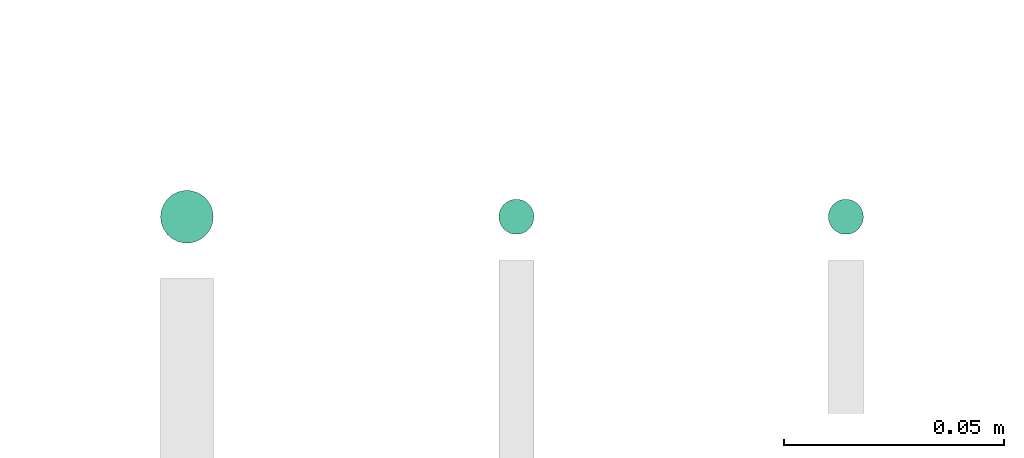
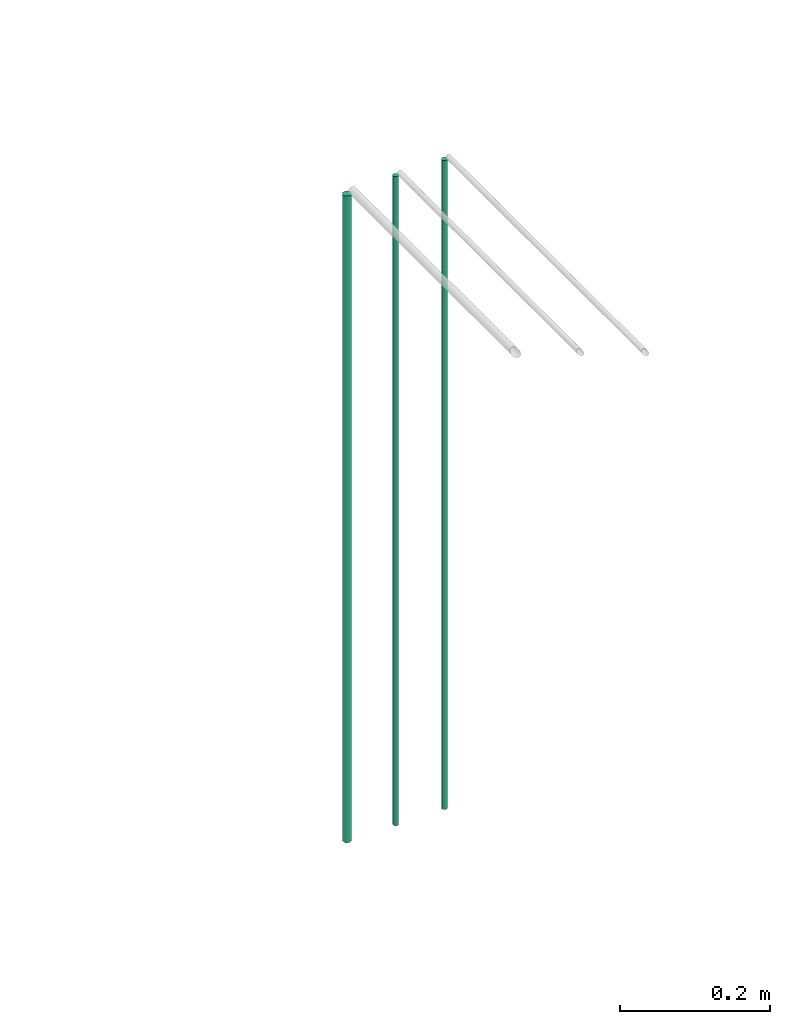
# One storey, part 2 of 65: 3 flow segments.
"""IFC2X3 building model written with IfcOpenShell, lengths in millimetres."""

from ifc_helpers import new_model, entity, si_unit, converted_unit, derived_unit, direction, frame, frame_2d, origin, origin_2d_with_axis, place, context, subcontext, project, spatial, circle, extrude, type_object, element, save


model = new_model("IFC2X3")

# Units and contexts
model_context = context("Model", 3, precision=0.01, world=origin(), true_north=direction((6.12303176911189e-17, 1.0)))
body_context = subcontext(model_context, "Body", "Model", "MODEL_VIEW")
ifc_project = project(units=[si_unit("LENGTHUNIT", "METRE", prefix="MILLI"), si_unit("AREAUNIT", "SQUARE_METRE"), si_unit("VOLUMEUNIT", "CUBIC_METRE"), converted_unit("PLANEANGLEUNIT", "DEGREE", entity("IfcRatioMeasure", 0.0174532925199433), si_unit("PLANEANGLEUNIT", "RADIAN"), dimensions=[0, 0, 0, 0, 0, 0, 0]), si_unit("MASSUNIT", "GRAM", prefix="KILO"), derived_unit("MASSDENSITYUNIT", [(si_unit("MASSUNIT", "GRAM", prefix="KILO"), 1), (si_unit("LENGTHUNIT", "METRE"), -3)]), derived_unit("MOMENTOFINERTIAUNIT", [(si_unit("LENGTHUNIT", "METRE"), 4)]), si_unit("TIMEUNIT", "SECOND"), si_unit("FREQUENCYUNIT", "HERTZ"), si_unit("THERMODYNAMICTEMPERATUREUNIT", "DEGREE_CELSIUS"), derived_unit("THERMALTRANSMITTANCEUNIT", [(si_unit("MASSUNIT", "GRAM", prefix="KILO"), 1), (si_unit("THERMODYNAMICTEMPERATUREUNIT", "KELVIN"), -1), (si_unit("TIMEUNIT", "SECOND"), -3)]), derived_unit("VOLUMETRICFLOWRATEUNIT", [(si_unit("LENGTHUNIT", "METRE"), 3), (si_unit("TIMEUNIT", "SECOND"), -1)]), derived_unit("MASSFLOWRATEUNIT", [(si_unit("MASSUNIT", "GRAM", prefix="KILO"), 1), (si_unit("TIMEUNIT", "SECOND"), -1)]), derived_unit("ROTATIONALFREQUENCYUNIT", [(si_unit("TIMEUNIT", "SECOND"), -1)]), si_unit("ELECTRICCURRENTUNIT", "AMPERE"), si_unit("ELECTRICVOLTAGEUNIT", "VOLT"), si_unit("POWERUNIT", "WATT"), si_unit("FORCEUNIT", "NEWTON", prefix="KILO"), si_unit("ILLUMINANCEUNIT", "LUX"), si_unit("LUMINOUSFLUXUNIT", "LUMEN"), si_unit("LUMINOUSINTENSITYUNIT", "CANDELA"), derived_unit("USERDEFINED", [(si_unit("MASSUNIT", "GRAM", prefix="KILO"), -1), (si_unit("LENGTHUNIT", "METRE"), -2), (si_unit("TIMEUNIT", "SECOND"), 3), (si_unit("LUMINOUSFLUXUNIT", "LUMEN"), 1)]), derived_unit("LINEARVELOCITYUNIT", [(si_unit("LENGTHUNIT", "METRE"), 1), (si_unit("TIMEUNIT", "SECOND"), -1)]), si_unit("PRESSUREUNIT", "PASCAL"), derived_unit("USERDEFINED", [(si_unit("LENGTHUNIT", "METRE"), -2), (si_unit("MASSUNIT", "GRAM", prefix="KILO"), 1), (si_unit("TIMEUNIT", "SECOND"), -2)]), derived_unit("LINEARFORCEUNIT", [(si_unit("MASSUNIT", "GRAM", prefix="KILO"), 1), (si_unit("LENGTHUNIT", "METRE"), 1), (si_unit("TIMEUNIT", "SECOND"), -2), (si_unit("LENGTHUNIT", "METRE"), -1)]), derived_unit("PLANARFORCEUNIT", [(si_unit("MASSUNIT", "GRAM", prefix="KILO"), 1), (si_unit("LENGTHUNIT", "METRE"), 1), (si_unit("TIMEUNIT", "SECOND"), -2), (si_unit("LENGTHUNIT", "METRE"), -2)])], contexts=[model_context])

# Site, building, storey
site_placement = place(None, frame((0.0, -0.00077364408347762, 0.0)))
site = spatial("IfcSite", under=ifc_project, at=site_placement, CompositionType="ELEMENT")
building_placement = place(site_placement, origin())
building = spatial("IfcBuilding", under=site, at=building_placement, CompositionType="ELEMENT")
storey_placement = place(building_placement, frame((0.0, 0.0, 19800.0)))
storey = spatial("IfcBuildingStorey", under=building, at=storey_placement, CompositionType="ELEMENT", Elevation=19800.0)

# Flow segments
pipe_segment_type = type_object("IfcPipeSegmentType", PredefinedType="NOTDEFINED")
flow_segment_placement = place(storey_placement, frame((20667.5132627186, 12707.5344917542, 1783.12693426895)))
element("IfcFlowSegment", 1, at=flow_segment_placement, inside=storey, type_object=pipe_segment_type, context=body_context, shape_type="SweptSolid", body=[
    extrude(circle(Radius=6.0, at=frame_2d((0.0, -2.16573425859679e-12), x_axis=(1.0, 0.0))), frame((7.59527223591454, 7.59527223591887, 0.0)), (0.0, 0.0, 1.0), 1052.87306573105),
])
for number, where in (
    (2, (20744.5132627183, 12709.5344917542, 1783.12693426895)),
    (3, (20819.5132627192, 12709.5344917542, 1783.12693426895)),
):
    element("IfcFlowSegment", number, at=place(storey_placement, frame(where)), inside=storey, type_object=pipe_segment_type, context=body_context, shape_type="SweptSolid", body=[
        extrude(circle(Radius=4.0, at=origin_2d_with_axis()), frame((5.59527223591499, 5.59527223591499, 0.0)), (0.0, 0.0, 1.0), 1056.87306573105),
    ])

save(model, "model.ifc")
